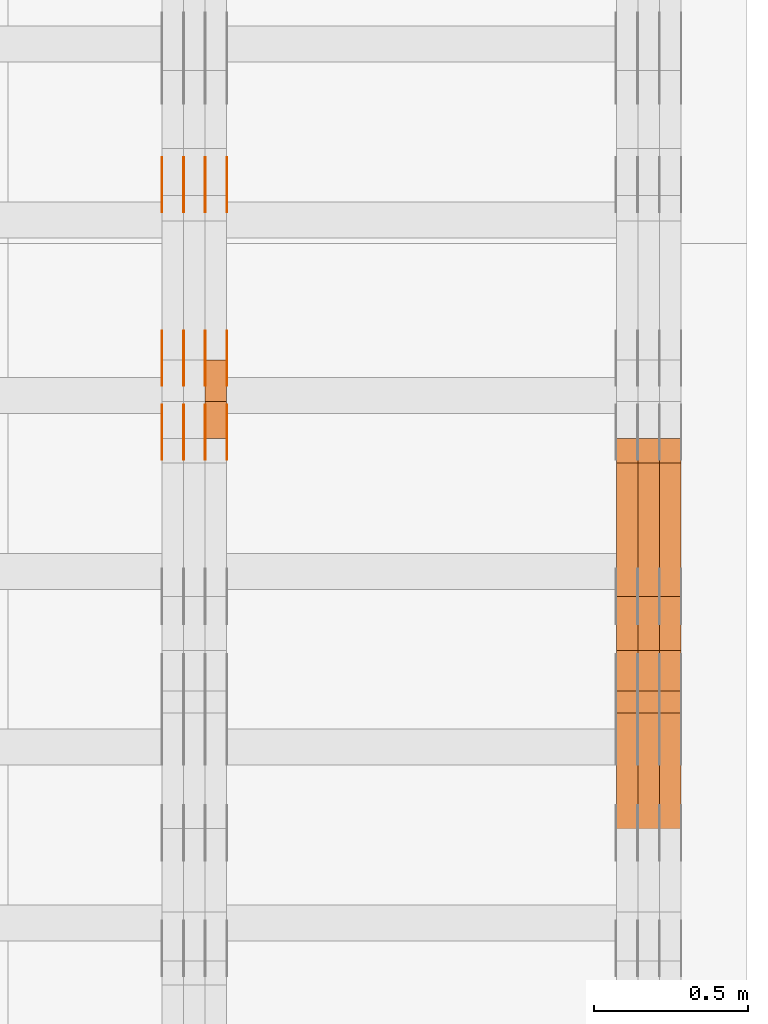
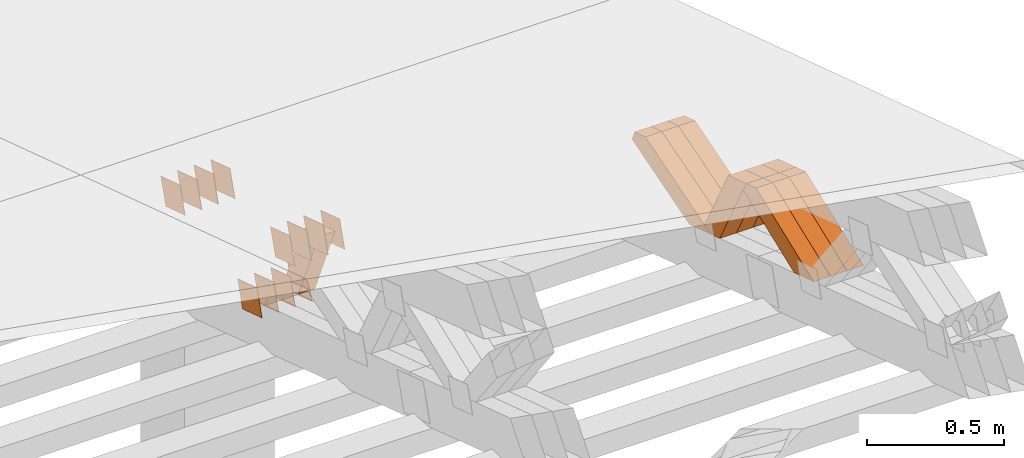
# One storey, part 371 of 385: 28 proxies.
"""IFC2X3 building model written with IfcOpenShell, lengths in millimetres."""

from ifc_helpers import new_model, entity, si_unit, converted_unit, derived_unit, direction, frame, origin, place, context, subcontext, project, spatial, polyline, outline, extrude, source, transform, mapped, material, type_object, type_shapes, element, save


model = new_model("IFC2X3")

# Units and contexts
model_context = context("Model", 3, precision=0.01, world=origin(), true_north=direction((6.12303176911189e-17, 1.0)))
body_context = subcontext(model_context, "Body", "Model", "MODEL_VIEW")
ifc_project = project(units=[si_unit("LENGTHUNIT", "METRE", prefix="MILLI"), si_unit("AREAUNIT", "SQUARE_METRE"), si_unit("VOLUMEUNIT", "CUBIC_METRE"), converted_unit("PLANEANGLEUNIT", "DEGREE", entity("IfcRatioMeasure", 0.0174532925199433), si_unit("PLANEANGLEUNIT", "RADIAN"), dimensions=[0, 0, 0, 0, 0, 0, 0]), si_unit("MASSUNIT", "GRAM", prefix="KILO"), derived_unit("MASSDENSITYUNIT", [(si_unit("MASSUNIT", "GRAM", prefix="KILO"), 1), (si_unit("LENGTHUNIT", "METRE"), -3)]), si_unit("TIMEUNIT", "SECOND"), si_unit("FREQUENCYUNIT", "HERTZ"), si_unit("THERMODYNAMICTEMPERATUREUNIT", "DEGREE_CELSIUS"), derived_unit("THERMALTRANSMITTANCEUNIT", [(si_unit("MASSUNIT", "GRAM", prefix="KILO"), 1), (si_unit("THERMODYNAMICTEMPERATUREUNIT", "KELVIN"), -1), (si_unit("TIMEUNIT", "SECOND"), -3)]), derived_unit("VOLUMETRICFLOWRATEUNIT", [(si_unit("LENGTHUNIT", "METRE"), 3), (si_unit("TIMEUNIT", "SECOND"), -1)]), si_unit("ELECTRICCURRENTUNIT", "AMPERE"), si_unit("ELECTRICVOLTAGEUNIT", "VOLT"), si_unit("POWERUNIT", "WATT"), si_unit("FORCEUNIT", "NEWTON", prefix="KILO"), si_unit("ILLUMINANCEUNIT", "LUX"), si_unit("LUMINOUSFLUXUNIT", "LUMEN"), si_unit("LUMINOUSINTENSITYUNIT", "CANDELA"), derived_unit("USERDEFINED", [(si_unit("MASSUNIT", "GRAM", prefix="KILO"), -1), (si_unit("LENGTHUNIT", "METRE"), -2), (si_unit("TIMEUNIT", "SECOND"), 3), (si_unit("LUMINOUSFLUXUNIT", "LUMEN"), 1)]), derived_unit("LINEARVELOCITYUNIT", [(si_unit("LENGTHUNIT", "METRE"), 1), (si_unit("TIMEUNIT", "SECOND"), -1)]), si_unit("PRESSUREUNIT", "PASCAL"), derived_unit("USERDEFINED", [(si_unit("LENGTHUNIT", "METRE"), -2), (si_unit("MASSUNIT", "GRAM", prefix="KILO"), 1), (si_unit("TIMEUNIT", "SECOND"), -2)])], contexts=[model_context])

# Site, building, storey
site_placement = place(None, origin())
site = spatial("IfcSite", under=ifc_project, at=site_placement, CompositionType="ELEMENT")
building_placement = place(site_placement, origin())
building = spatial("IfcBuilding", under=site, at=building_placement, CompositionType="ELEMENT")
storey_placement = place(building_placement, origin())
storey = spatial("IfcBuildingStorey", under=building, at=storey_placement, Name="Default", CompositionType="ELEMENT", Elevation=0.0)

# Proxies
ifc_material_1 = material(Name="IfcSurfaceStyle #598006")
building_element_proxy_type_1 = type_object("IfcBuildingElementProxyType", Name="T2-W30 598004", PredefinedType="NOTDEFINED", material=ifc_material_1)
shared_shape_1 = source(origin(), body_context, "Body", "SweptSolid", [
    extrude(outline(polyline([(-319.322304176575, -47.5000259045904), (133.154090927094, -47.5000259045904), (191.489196707701, 6.99403755251016e-06), (197.330697834052, 47.5000224075717), (-202.651681292271, 47.5000224075717), (-319.322304176575, -47.5000259045904)])), frame((197.330834478517, 47.5000608592405, 0.0), z_axis=(0.0, 0.0, 1.0), x_axis=(-1.0, 0.0, 0.0)), (0.0, 0.0, 1.0), 70.0),
])
type_shapes(building_element_proxy_type_1, [shared_shape_1])
proxy_1_placement = place(building_placement, frame((49860.0, 22312.5352975627, 1720.70362673362), z_axis=(-1.0, 0.0, 0.0), x_axis=(0.0, -0.932610696879359, -0.360884036868072)))
element("IfcBuildingElementProxy", 1, at=proxy_1_placement, inside=storey, type_object=building_element_proxy_type_1, material=ifc_material_1, Name="T2-W30", context=body_context, shape_type="MappedRepresentation", body=[
    mapped(shared_shape_1, transform((0.0, 0.0, 0.0), scale=1.0)),
])
ifc_material_2 = material(Name="IfcSurfaceStyle #597940")
building_element_proxy_type_2 = type_object("IfcBuildingElementProxyType", Name="T2-W30 597938", PredefinedType="NOTDEFINED", material=ifc_material_2)
shared_shape_2 = source(origin(), body_context, "Body", "SweptSolid", [
    extrude(outline(polyline([(-319.322304176575, -47.5000259045904), (133.154090927094, -47.5000259045904), (191.489196707701, 6.99403755251016e-06), (197.330697834052, 47.5000224075717), (-202.651681292271, 47.5000224075717), (-319.322304176575, -47.5000259045904)])), frame((197.330834478517, 47.5000608592405, 0.0), z_axis=(0.0, 0.0, 1.0), x_axis=(-1.0, 0.0, 0.0)), (0.0, 0.0, 1.0), 70.0),
])
type_shapes(building_element_proxy_type_2, [shared_shape_2])
proxy_2_placement = place(building_placement, frame((49790.0, 22312.5352975627, 1720.70362673362), z_axis=(-1.0, 0.0, 0.0), x_axis=(0.0, -0.932610696879359, -0.360884036868072)))
element("IfcBuildingElementProxy", 2, at=proxy_2_placement, inside=storey, type_object=building_element_proxy_type_2, material=ifc_material_2, Name="T2-W30", context=body_context, shape_type="MappedRepresentation", body=[
    mapped(shared_shape_2, transform((0.0, 0.0, 0.0), scale=1.0)),
])
ifc_material_3 = material(Name="IfcSurfaceStyle #597874")
building_element_proxy_type_3 = type_object("IfcBuildingElementProxyType", Name="T2-W30 597872", PredefinedType="NOTDEFINED", material=ifc_material_3)
shared_shape_3 = source(origin(), body_context, "Body", "SweptSolid", [
    extrude(outline(polyline([(-319.322304176575, -47.5000259045904), (133.154090927094, -47.5000259045904), (191.489196707701, 6.99403755251016e-06), (197.330697834052, 47.5000224075717), (-202.651681292271, 47.5000224075717), (-319.322304176575, -47.5000259045904)])), frame((197.330834478517, 47.5000608592405, 0.0), z_axis=(0.0, 0.0, 1.0), x_axis=(-1.0, 0.0, 0.0)), (0.0, 0.0, 1.0), 70.0),
])
type_shapes(building_element_proxy_type_3, [shared_shape_3])
proxy_3_placement = place(building_placement, frame((49720.0, 22312.5352975627, 1720.70362673362), z_axis=(-1.0, 0.0, 0.0), x_axis=(0.0, -0.932610696879359, -0.360884036868072)))
element("IfcBuildingElementProxy", 3, at=proxy_3_placement, inside=storey, type_object=building_element_proxy_type_3, material=ifc_material_3, Name="T2-W30", context=body_context, shape_type="MappedRepresentation", body=[
    mapped(shared_shape_3, transform((0.0, 0.0, 0.0), scale=1.0)),
])
ifc_material_4 = material(Name="IfcSurfaceStyle #597610")
building_element_proxy_type_4 = type_object("IfcBuildingElementProxyType", Name="T2-W41 597608", PredefinedType="NOTDEFINED", material=ifc_material_4)
shared_shape_4 = source(origin(), body_context, "Body", "SweptSolid", [
    extrude(outline(polyline([(-190.064783497519, -47.5001011048749), (182.590736871656, -47.5001011048749), (172.978793750747, 0.000111395300689243), (123.505951450908, 47.5000454072246), (-289.010698575792, 47.5000454072246), (-190.064783497519, -47.5001011048749)])), frame((182.590736871656, 47.5001973817447, 0.0), z_axis=(0.0, 0.0, 1.0), x_axis=(-1.0, 0.0, 0.0)), (0.0, 0.0, 1.0), 70.0),
])
type_shapes(building_element_proxy_type_4, [shared_shape_4])
proxy_4_placement = place(building_placement, frame((49860.0, 22512.5506969063, 1347.13648051689), z_axis=(-1.0, 0.0, 0.0), x_axis=(0.0, -0.472020158706979, 0.881587755004706)))
element("IfcBuildingElementProxy", 4, at=proxy_4_placement, inside=storey, type_object=building_element_proxy_type_4, material=ifc_material_4, Name="T2-W41", context=body_context, shape_type="MappedRepresentation", body=[
    mapped(shared_shape_4, transform((0.0, 0.0, 0.0), scale=1.0)),
])
ifc_material_5 = material(Name="IfcSurfaceStyle #597544")
building_element_proxy_type_5 = type_object("IfcBuildingElementProxyType", Name="T2-W41 597542", PredefinedType="NOTDEFINED", material=ifc_material_5)
shared_shape_5 = source(origin(), body_context, "Body", "SweptSolid", [
    extrude(outline(polyline([(-190.064783497519, -47.5001011048749), (182.590736871656, -47.5001011048749), (172.978793750747, 0.000111395300689243), (123.505951450908, 47.5000454072246), (-289.010698575792, 47.5000454072246), (-190.064783497519, -47.5001011048749)])), frame((182.590736871656, 47.5001973817447, 0.0), z_axis=(0.0, 0.0, 1.0), x_axis=(-1.0, 0.0, 0.0)), (0.0, 0.0, 1.0), 70.0),
])
type_shapes(building_element_proxy_type_5, [shared_shape_5])
proxy_5_placement = place(building_placement, frame((49790.0, 22512.5506969063, 1347.13648051689), z_axis=(-1.0, 0.0, 0.0), x_axis=(0.0, -0.472020158706979, 0.881587755004706)))
element("IfcBuildingElementProxy", 5, at=proxy_5_placement, inside=storey, type_object=building_element_proxy_type_5, material=ifc_material_5, Name="T2-W41", context=body_context, shape_type="MappedRepresentation", body=[
    mapped(shared_shape_5, transform((0.0, 0.0, 0.0), scale=1.0)),
])
ifc_material_6 = material(Name="IfcSurfaceStyle #597478")
building_element_proxy_type_6 = type_object("IfcBuildingElementProxyType", Name="T2-W41 597476", PredefinedType="NOTDEFINED", material=ifc_material_6)
shared_shape_6 = source(origin(), body_context, "Body", "SweptSolid", [
    extrude(outline(polyline([(-190.064783497519, -47.5001011048749), (182.590736871656, -47.5001011048749), (172.978793750747, 0.000111395300689243), (123.505951450908, 47.5000454072246), (-289.010698575792, 47.5000454072246), (-190.064783497519, -47.5001011048749)])), frame((182.590736871656, 47.5001973817447, 0.0), z_axis=(0.0, 0.0, 1.0), x_axis=(-1.0, 0.0, 0.0)), (0.0, 0.0, 1.0), 70.0),
])
type_shapes(building_element_proxy_type_6, [shared_shape_6])
proxy_6_placement = place(building_placement, frame((49720.0, 22512.5506969063, 1347.13648051689), z_axis=(-1.0, 0.0, 0.0), x_axis=(0.0, -0.472020158706979, 0.881587755004706)))
element("IfcBuildingElementProxy", 6, at=proxy_6_placement, inside=storey, type_object=building_element_proxy_type_6, material=ifc_material_6, Name="T2-W41", context=body_context, shape_type="MappedRepresentation", body=[
    mapped(shared_shape_6, transform((0.0, 0.0, 0.0), scale=1.0)),
])
ifc_material_7 = material(Name="IfcSurfaceStyle #597214")
building_element_proxy_type_7 = type_object("IfcBuildingElementProxyType", Name="T2-W23 597212", PredefinedType="NOTDEFINED", material=ifc_material_7)
shared_shape_7 = source(origin(), body_context, "Body", "SweptSolid", [
    extrude(outline(polyline([(-356.808656505462, -47.5000180192671), (144.726334557508, -47.5000180192671), (213.258834104997, -2.90494310381195e-05), (218.567145253444, 47.5000325439826), (-219.743657410487, 47.5000325439827), (-356.808656505462, -47.5000180192671)])), frame((218.567145253444, 47.5000325439826, 0.0), z_axis=(0.0, 0.0, 1.0), x_axis=(-1.0, 0.0, 0.0)), (0.0, 0.0, 1.0), 70.0),
])
type_shapes(building_element_proxy_type_7, [shared_shape_7])
proxy_7_placement = place(building_placement, frame((49860.0, 23128.2626953125, 1452.63940429688), z_axis=(-1.0, 0.0, 0.0), x_axis=(0.0, -0.957692700226705, -0.287792793399143)))
element("IfcBuildingElementProxy", 7, at=proxy_7_placement, inside=storey, type_object=building_element_proxy_type_7, material=ifc_material_7, Name="T2-W23", context=body_context, shape_type="MappedRepresentation", body=[
    mapped(shared_shape_7, transform((0.0, 0.0, 0.0), scale=1.0)),
])
ifc_material_8 = material(Name="IfcSurfaceStyle #597148")
building_element_proxy_type_8 = type_object("IfcBuildingElementProxyType", Name="T2-W23 597146", PredefinedType="NOTDEFINED", material=ifc_material_8)
shared_shape_8 = source(origin(), body_context, "Body", "SweptSolid", [
    extrude(outline(polyline([(-356.808656505462, -47.5000180192671), (144.726334557508, -47.5000180192671), (213.258834104997, -2.90494310381195e-05), (218.567145253444, 47.5000325439826), (-219.743657410487, 47.5000325439827), (-356.808656505462, -47.5000180192671)])), frame((218.567145253444, 47.5000325439826, 0.0), z_axis=(0.0, 0.0, 1.0), x_axis=(-1.0, 0.0, 0.0)), (0.0, 0.0, 1.0), 70.0),
])
type_shapes(building_element_proxy_type_8, [shared_shape_8])
proxy_8_placement = place(building_placement, frame((49790.0, 23128.2626953125, 1452.63940429688), z_axis=(-1.0, 0.0, 0.0), x_axis=(0.0, -0.957692700226705, -0.287792793399143)))
element("IfcBuildingElementProxy", 8, at=proxy_8_placement, inside=storey, type_object=building_element_proxy_type_8, material=ifc_material_8, Name="T2-W23", context=body_context, shape_type="MappedRepresentation", body=[
    mapped(shared_shape_8, transform((0.0, 0.0, 0.0), scale=1.0)),
])
ifc_material_9 = material(Name="IfcSurfaceStyle #597082")
building_element_proxy_type_9 = type_object("IfcBuildingElementProxyType", Name="T2-W23 597080", PredefinedType="NOTDEFINED", material=ifc_material_9)
shared_shape_9 = source(origin(), body_context, "Body", "SweptSolid", [
    extrude(outline(polyline([(-356.808656505462, -47.5000180192671), (144.726334557508, -47.5000180192671), (213.258834104997, -2.90494310381195e-05), (218.567145253444, 47.5000325439826), (-219.743657410487, 47.5000325439827), (-356.808656505462, -47.5000180192671)])), frame((218.567145253444, 47.5000325439826, 0.0), z_axis=(0.0, 0.0, 1.0), x_axis=(-1.0, 0.0, 0.0)), (0.0, 0.0, 1.0), 70.0),
])
type_shapes(building_element_proxy_type_9, [shared_shape_9])
proxy_9_placement = place(building_placement, frame((49720.0, 23128.2626953125, 1452.63940429688), z_axis=(-1.0, 0.0, 0.0), x_axis=(0.0, -0.957692700226705, -0.287792793399143)))
element("IfcBuildingElementProxy", 9, at=proxy_9_placement, inside=storey, type_object=building_element_proxy_type_9, material=ifc_material_9, Name="T2-W23", context=body_context, shape_type="MappedRepresentation", body=[
    mapped(shared_shape_9, transform((0.0, 0.0, 0.0), scale=1.0)),
])
ifc_material_10 = material(Name="IfcSurfaceStyle #575238")
building_element_proxy_type_10 = type_object("IfcBuildingElementProxyType", PredefinedType="NOTDEFINED", material=ifc_material_10)
shared_shape_10 = source(origin(), body_context, "Body", "SweptSolid", [
    extrude(outline(polyline([(-74.9998888504569, -59.9999264677525), (74.999884859074, -59.9999264677525), (74.9998699895559, 59.9999264677525), (-74.999865998173, 59.9999264677525), (-74.9998888504569, -59.9999264677525)])), frame((74.9999170714918, 60.0000016373507, 0.0), z_axis=(0.0, 0.0, 1.0), x_axis=(-1.0, 0.0, 0.0)), (0.0, 0.0, 1.0), 1.3),
])
type_shapes(building_element_proxy_type_10, [shared_shape_10])
proxy_10_placement = place(building_placement, frame((48386.3, 23182.5962361838, 1409.76695322432), z_axis=(-1.0, 0.0, 0.0), x_axis=(0.0, -0.951056516295154, 0.309016994374948)))
element("IfcBuildingElementProxy", 10, at=proxy_10_placement, inside=storey, type_object=building_element_proxy_type_10, material=ifc_material_10, context=body_context, shape_type="MappedRepresentation", body=[
    mapped(shared_shape_10, transform((0.0, 0.0, 0.0), scale=1.0)),
])
ifc_material_11 = material(Name="IfcSurfaceStyle #575181")
building_element_proxy_type_11 = type_object("IfcBuildingElementProxyType", PredefinedType="NOTDEFINED", material=ifc_material_11)
shared_shape_11 = source(origin(), body_context, "Body", "SweptSolid", [
    extrude(outline(polyline([(-74.9998888504569, -59.9999264677525), (74.999884859074, -59.9999264677525), (74.9998699895559, 59.9999264677525), (-74.999865998173, 59.9999264677525), (-74.9998888504569, -59.9999264677525)])), frame((74.9999170714918, 60.0000016373507, 0.0), z_axis=(0.0, 0.0, 1.0), x_axis=(-1.0, 0.0, 0.0)), (0.0, 0.0, 1.0), 1.3),
])
type_shapes(building_element_proxy_type_11, [shared_shape_11])
proxy_11_placement = place(building_placement, frame((48315.0, 23182.5962361838, 1409.76695322432), z_axis=(-1.0, 0.0, 0.0), x_axis=(0.0, -0.951056516295154, 0.309016994374948)))
element("IfcBuildingElementProxy", 11, at=proxy_11_placement, inside=storey, type_object=building_element_proxy_type_11, material=ifc_material_11, context=body_context, shape_type="MappedRepresentation", body=[
    mapped(shared_shape_11, transform((0.0, 0.0, 0.0), scale=1.0)),
])
ifc_material_12 = material(Name="IfcSurfaceStyle #575124")
building_element_proxy_type_12 = type_object("IfcBuildingElementProxyType", PredefinedType="NOTDEFINED", material=ifc_material_12)
shared_shape_12 = source(origin(), body_context, "Body", "SweptSolid", [
    extrude(outline(polyline([(-74.9998888504569, -59.9999264677525), (74.999884859074, -59.9999264677525), (74.9998699895559, 59.9999264677525), (-74.999865998173, 59.9999264677525), (-74.9998888504569, -59.9999264677525)])), frame((74.9999170714918, 60.0000016373507, 0.0), z_axis=(0.0, 0.0, 1.0), x_axis=(-1.0, 0.0, 0.0)), (0.0, 0.0, 1.0), 1.3),
])
type_shapes(building_element_proxy_type_12, [shared_shape_12])
proxy_12_placement = place(building_placement, frame((48316.3, 23182.5962361838, 1409.76695322432), z_axis=(-1.0, 0.0, 0.0), x_axis=(0.0, -0.951056516295154, 0.309016994374948)))
element("IfcBuildingElementProxy", 12, at=proxy_12_placement, inside=storey, type_object=building_element_proxy_type_12, material=ifc_material_12, context=body_context, shape_type="MappedRepresentation", body=[
    mapped(shared_shape_12, transform((0.0, 0.0, 0.0), scale=1.0)),
])
ifc_material_13 = material(Name="IfcSurfaceStyle #575067")
building_element_proxy_type_13 = type_object("IfcBuildingElementProxyType", PredefinedType="NOTDEFINED", material=ifc_material_13)
shared_shape_13 = source(origin(), body_context, "Body", "SweptSolid", [
    extrude(outline(polyline([(-74.9998888504569, -59.9999264677525), (74.999884859074, -59.9999264677525), (74.9998699895559, 59.9999264677525), (-74.999865998173, 59.9999264677525), (-74.9998888504569, -59.9999264677525)])), frame((74.9999170714918, 60.0000016373507, 0.0), z_axis=(0.0, 0.0, 1.0), x_axis=(-1.0, 0.0, 0.0)), (0.0, 0.0, 1.0), 1.29999999999999),
])
type_shapes(building_element_proxy_type_13, [shared_shape_13])
proxy_13_placement = place(building_placement, frame((48245.0, 23182.5962361838, 1409.76695322432), z_axis=(-1.0, 0.0, 0.0), x_axis=(0.0, -0.951056516295154, 0.309016994374948)))
element("IfcBuildingElementProxy", 13, at=proxy_13_placement, inside=storey, type_object=building_element_proxy_type_13, material=ifc_material_13, context=body_context, shape_type="MappedRepresentation", body=[
    mapped(shared_shape_13, transform((0.0, 0.0, 0.0), scale=1.0)),
])
ifc_material_14 = material(Name="IfcSurfaceStyle #575010")
building_element_proxy_type_14 = type_object("IfcBuildingElementProxyType", PredefinedType="NOTDEFINED", material=ifc_material_14)
shared_shape_14 = source(origin(), body_context, "Body", "SweptSolid", [
    extrude(outline(polyline([(-74.9998888504569, -59.9999264677525), (74.999884859074, -59.9999264677525), (74.9998699895559, 59.9999264677525), (-74.999865998173, 59.9999264677525), (-74.9998888504569, -59.9999264677525)])), frame((74.9999170714918, 60.0000016373507, 0.0), z_axis=(0.0, 0.0, 1.0), x_axis=(-1.0, 0.0, 0.0)), (0.0, 0.0, 1.0), 1.29999999999999),
])
type_shapes(building_element_proxy_type_14, [shared_shape_14])
proxy_14_placement = place(building_placement, frame((48246.3, 23182.5962361838, 1409.76695322432), z_axis=(-1.0, 0.0, 0.0), x_axis=(0.0, -0.951056516295154, 0.309016994374948)))
element("IfcBuildingElementProxy", 14, at=proxy_14_placement, inside=storey, type_object=building_element_proxy_type_14, material=ifc_material_14, context=body_context, shape_type="MappedRepresentation", body=[
    mapped(shared_shape_14, transform((0.0, 0.0, 0.0), scale=1.0)),
])
ifc_material_15 = material(Name="IfcSurfaceStyle #574953")
building_element_proxy_type_15 = type_object("IfcBuildingElementProxyType", PredefinedType="NOTDEFINED", material=ifc_material_15)
shared_shape_15 = source(origin(), body_context, "Body", "SweptSolid", [
    extrude(outline(polyline([(-74.9998888504569, -59.9999264677525), (74.999884859074, -59.9999264677525), (74.9998699895559, 59.9999264677525), (-74.999865998173, 59.9999264677525), (-74.9998888504569, -59.9999264677525)])), frame((74.9999170714918, 60.0000016373507, 0.0), z_axis=(0.0, 0.0, 1.0), x_axis=(-1.0, 0.0, 0.0)), (0.0, 0.0, 1.0), 1.29999999999999),
])
type_shapes(building_element_proxy_type_15, [shared_shape_15])
proxy_15_placement = place(building_placement, frame((48175.0, 23182.5962361838, 1409.76695322432), z_axis=(-1.0, 0.0, 0.0), x_axis=(0.0, -0.951056516295154, 0.309016994374948)))
element("IfcBuildingElementProxy", 15, at=proxy_15_placement, inside=storey, type_object=building_element_proxy_type_15, material=ifc_material_15, context=body_context, shape_type="MappedRepresentation", body=[
    mapped(shared_shape_15, transform((0.0, 0.0, 0.0), scale=1.0)),
])
ifc_material_16 = material(Name="IfcSurfaceStyle #574896")
building_element_proxy_type_16 = type_object("IfcBuildingElementProxyType", PredefinedType="NOTDEFINED", material=ifc_material_16)
shared_shape_16 = source(origin(), body_context, "Body", "SweptSolid", [
    extrude(outline(polyline([(-75.000111611545, -60.0000599592451), (75.0000887592491, -60.0000599592451), (75.000111611545, 60.0000599592451), (-75.0000887592492, 60.0000599592451), (-75.000111611545, -60.0000599592451)])), frame((75.000111611545, 60.0000599592451, 0.0), z_axis=(0.0, 0.0, 1.0), x_axis=(-1.0, 0.0, 0.0)), (0.0, 0.0, 1.0), 1.3),
])
type_shapes(building_element_proxy_type_16, [shared_shape_16])
proxy_16_placement = place(building_placement, frame((48386.3, 23422.738257852, 1031.33757447264), z_axis=(-1.0, 0.0, 0.0), x_axis=(0.0, -0.951056516295124, 0.309016994375039)))
element("IfcBuildingElementProxy", 16, at=proxy_16_placement, inside=storey, type_object=building_element_proxy_type_16, material=ifc_material_16, context=body_context, shape_type="MappedRepresentation", body=[
    mapped(shared_shape_16, transform((0.0, 0.0, 0.0), scale=1.0)),
])
ifc_material_17 = material(Name="IfcSurfaceStyle #574839")
building_element_proxy_type_17 = type_object("IfcBuildingElementProxyType", PredefinedType="NOTDEFINED", material=ifc_material_17)
shared_shape_17 = source(origin(), body_context, "Body", "SweptSolid", [
    extrude(outline(polyline([(-75.000111611545, -60.0000599592451), (75.0000887592491, -60.0000599592451), (75.000111611545, 60.0000599592451), (-75.0000887592492, 60.0000599592451), (-75.000111611545, -60.0000599592451)])), frame((75.000111611545, 60.0000599592451, 0.0), z_axis=(0.0, 0.0, 1.0), x_axis=(-1.0, 0.0, 0.0)), (0.0, 0.0, 1.0), 1.3),
])
type_shapes(building_element_proxy_type_17, [shared_shape_17])
proxy_17_placement = place(building_placement, frame((48315.0, 23422.738257852, 1031.33757447264), z_axis=(-1.0, 0.0, 0.0), x_axis=(0.0, -0.951056516295124, 0.309016994375039)))
element("IfcBuildingElementProxy", 17, at=proxy_17_placement, inside=storey, type_object=building_element_proxy_type_17, material=ifc_material_17, context=body_context, shape_type="MappedRepresentation", body=[
    mapped(shared_shape_17, transform((0.0, 0.0, 0.0), scale=1.0)),
])
ifc_material_18 = material(Name="IfcSurfaceStyle #574782")
building_element_proxy_type_18 = type_object("IfcBuildingElementProxyType", PredefinedType="NOTDEFINED", material=ifc_material_18)
shared_shape_18 = source(origin(), body_context, "Body", "SweptSolid", [
    extrude(outline(polyline([(-75.000111611545, -60.0000599592451), (75.0000887592491, -60.0000599592451), (75.000111611545, 60.0000599592451), (-75.0000887592492, 60.0000599592451), (-75.000111611545, -60.0000599592451)])), frame((75.000111611545, 60.0000599592451, 0.0), z_axis=(0.0, 0.0, 1.0), x_axis=(-1.0, 0.0, 0.0)), (0.0, 0.0, 1.0), 1.3),
])
type_shapes(building_element_proxy_type_18, [shared_shape_18])
proxy_18_placement = place(building_placement, frame((48316.3, 23422.738257852, 1031.33757447264), z_axis=(-1.0, 0.0, 0.0), x_axis=(0.0, -0.951056516295124, 0.309016994375039)))
element("IfcBuildingElementProxy", 18, at=proxy_18_placement, inside=storey, type_object=building_element_proxy_type_18, material=ifc_material_18, context=body_context, shape_type="MappedRepresentation", body=[
    mapped(shared_shape_18, transform((0.0, 0.0, 0.0), scale=1.0)),
])
ifc_material_19 = material(Name="IfcSurfaceStyle #574725")
building_element_proxy_type_19 = type_object("IfcBuildingElementProxyType", PredefinedType="NOTDEFINED", material=ifc_material_19)
shared_shape_19 = source(origin(), body_context, "Body", "SweptSolid", [
    extrude(outline(polyline([(-75.000111611545, -60.0000599592451), (75.0000887592491, -60.0000599592451), (75.000111611545, 60.0000599592451), (-75.0000887592492, 60.0000599592451), (-75.000111611545, -60.0000599592451)])), frame((75.000111611545, 60.0000599592451, 0.0), z_axis=(0.0, 0.0, 1.0), x_axis=(-1.0, 0.0, 0.0)), (0.0, 0.0, 1.0), 1.29999999999999),
])
type_shapes(building_element_proxy_type_19, [shared_shape_19])
proxy_19_placement = place(building_placement, frame((48245.0, 23422.738257852, 1031.33757447264), z_axis=(-1.0, 0.0, 0.0), x_axis=(0.0, -0.951056516295124, 0.309016994375039)))
element("IfcBuildingElementProxy", 19, at=proxy_19_placement, inside=storey, type_object=building_element_proxy_type_19, material=ifc_material_19, context=body_context, shape_type="MappedRepresentation", body=[
    mapped(shared_shape_19, transform((0.0, 0.0, 0.0), scale=1.0)),
])
ifc_material_20 = material(Name="IfcSurfaceStyle #574668")
building_element_proxy_type_20 = type_object("IfcBuildingElementProxyType", PredefinedType="NOTDEFINED", material=ifc_material_20)
shared_shape_20 = source(origin(), body_context, "Body", "SweptSolid", [
    extrude(outline(polyline([(-75.000111611545, -60.0000599592451), (75.0000887592491, -60.0000599592451), (75.000111611545, 60.0000599592451), (-75.0000887592492, 60.0000599592451), (-75.000111611545, -60.0000599592451)])), frame((75.000111611545, 60.0000599592451, 0.0), z_axis=(0.0, 0.0, 1.0), x_axis=(-1.0, 0.0, 0.0)), (0.0, 0.0, 1.0), 1.29999999999999),
])
type_shapes(building_element_proxy_type_20, [shared_shape_20])
proxy_20_placement = place(building_placement, frame((48246.3, 23422.738257852, 1031.33757447264), z_axis=(-1.0, 0.0, 0.0), x_axis=(0.0, -0.951056516295124, 0.309016994375039)))
element("IfcBuildingElementProxy", 20, at=proxy_20_placement, inside=storey, type_object=building_element_proxy_type_20, material=ifc_material_20, context=body_context, shape_type="MappedRepresentation", body=[
    mapped(shared_shape_20, transform((0.0, 0.0, 0.0), scale=1.0)),
])
ifc_material_21 = material(Name="IfcSurfaceStyle #574611")
building_element_proxy_type_21 = type_object("IfcBuildingElementProxyType", PredefinedType="NOTDEFINED", material=ifc_material_21)
shared_shape_21 = source(origin(), body_context, "Body", "SweptSolid", [
    extrude(outline(polyline([(-75.000111611545, -60.0000599592451), (75.0000887592491, -60.0000599592451), (75.000111611545, 60.0000599592451), (-75.0000887592492, 60.0000599592451), (-75.000111611545, -60.0000599592451)])), frame((75.000111611545, 60.0000599592451, 0.0), z_axis=(0.0, 0.0, 1.0), x_axis=(-1.0, 0.0, 0.0)), (0.0, 0.0, 1.0), 1.29999999999999),
])
type_shapes(building_element_proxy_type_21, [shared_shape_21])
proxy_21_placement = place(building_placement, frame((48175.0, 23422.738257852, 1031.33757447264), z_axis=(-1.0, 0.0, 0.0), x_axis=(0.0, -0.951056516295124, 0.309016994375039)))
element("IfcBuildingElementProxy", 21, at=proxy_21_placement, inside=storey, type_object=building_element_proxy_type_21, material=ifc_material_21, context=body_context, shape_type="MappedRepresentation", body=[
    mapped(shared_shape_21, transform((0.0, 0.0, 0.0), scale=1.0)),
])
ifc_material_22 = material(Name="IfcSurfaceStyle #574212")
building_element_proxy_type_22 = type_object("IfcBuildingElementProxyType", PredefinedType="NOTDEFINED", material=ifc_material_22)
shared_shape_22 = source(origin(), body_context, "Body", "SweptSolid", [
    extrude(outline(polyline([(-74.9999766548731, -60.0000019113547), (75.000223715922, -60.0000019113547), (74.9997444633404, 60.0000019113548), (-74.9999915243893, 60.0000019113547), (-74.9999766548731, -60.0000019113547)])), frame((75.0002237159219, 60.0000770809529, 0.0), z_axis=(0.0, 0.0, 1.0), x_axis=(-1.0, 0.0, 0.0)), (0.0, 0.0, 1.0), 1.3),
])
type_shapes(building_element_proxy_type_22, [shared_shape_22])
proxy_22_placement = place(building_placement, frame((48386.3, 23985.88473314, 1148.76266928562), z_axis=(-1.0, 0.0, 0.0), x_axis=(0.0, -0.951056516295154, 0.309016994374948)))
element("IfcBuildingElementProxy", 22, at=proxy_22_placement, inside=storey, type_object=building_element_proxy_type_22, material=ifc_material_22, context=body_context, shape_type="MappedRepresentation", body=[
    mapped(shared_shape_22, transform((0.0, 0.0, 0.0), scale=1.0)),
])
ifc_material_23 = material(Name="IfcSurfaceStyle #574155")
building_element_proxy_type_23 = type_object("IfcBuildingElementProxyType", PredefinedType="NOTDEFINED", material=ifc_material_23)
shared_shape_23 = source(origin(), body_context, "Body", "SweptSolid", [
    extrude(outline(polyline([(-74.9999766548731, -60.0000019113547), (75.000223715922, -60.0000019113547), (74.9997444633404, 60.0000019113548), (-74.9999915243893, 60.0000019113547), (-74.9999766548731, -60.0000019113547)])), frame((75.0002237159219, 60.0000770809529, 0.0), z_axis=(0.0, 0.0, 1.0), x_axis=(-1.0, 0.0, 0.0)), (0.0, 0.0, 1.0), 1.3),
])
type_shapes(building_element_proxy_type_23, [shared_shape_23])
proxy_23_placement = place(building_placement, frame((48315.0, 23985.88473314, 1148.76266928562), z_axis=(-1.0, 0.0, 0.0), x_axis=(0.0, -0.951056516295154, 0.309016994374948)))
element("IfcBuildingElementProxy", 23, at=proxy_23_placement, inside=storey, type_object=building_element_proxy_type_23, material=ifc_material_23, context=body_context, shape_type="MappedRepresentation", body=[
    mapped(shared_shape_23, transform((0.0, 0.0, 0.0), scale=1.0)),
])
ifc_material_24 = material(Name="IfcSurfaceStyle #574098")
building_element_proxy_type_24 = type_object("IfcBuildingElementProxyType", PredefinedType="NOTDEFINED", material=ifc_material_24)
shared_shape_24 = source(origin(), body_context, "Body", "SweptSolid", [
    extrude(outline(polyline([(-74.9999766548731, -60.0000019113547), (75.000223715922, -60.0000019113547), (74.9997444633404, 60.0000019113548), (-74.9999915243893, 60.0000019113547), (-74.9999766548731, -60.0000019113547)])), frame((75.0002237159219, 60.0000770809529, 0.0), z_axis=(0.0, 0.0, 1.0), x_axis=(-1.0, 0.0, 0.0)), (0.0, 0.0, 1.0), 1.3),
])
type_shapes(building_element_proxy_type_24, [shared_shape_24])
proxy_24_placement = place(building_placement, frame((48316.3, 23985.88473314, 1148.76266928562), z_axis=(-1.0, 0.0, 0.0), x_axis=(0.0, -0.951056516295154, 0.309016994374948)))
element("IfcBuildingElementProxy", 24, at=proxy_24_placement, inside=storey, type_object=building_element_proxy_type_24, material=ifc_material_24, context=body_context, shape_type="MappedRepresentation", body=[
    mapped(shared_shape_24, transform((0.0, 0.0, 0.0), scale=1.0)),
])
ifc_material_25 = material(Name="IfcSurfaceStyle #574041")
building_element_proxy_type_25 = type_object("IfcBuildingElementProxyType", PredefinedType="NOTDEFINED", material=ifc_material_25)
shared_shape_25 = source(origin(), body_context, "Body", "SweptSolid", [
    extrude(outline(polyline([(-74.9999766548731, -60.0000019113547), (75.000223715922, -60.0000019113547), (74.9997444633404, 60.0000019113548), (-74.9999915243893, 60.0000019113547), (-74.9999766548731, -60.0000019113547)])), frame((75.0002237159219, 60.0000770809529, 0.0), z_axis=(0.0, 0.0, 1.0), x_axis=(-1.0, 0.0, 0.0)), (0.0, 0.0, 1.0), 1.29999999999999),
])
type_shapes(building_element_proxy_type_25, [shared_shape_25])
proxy_25_placement = place(building_placement, frame((48245.0, 23985.88473314, 1148.76266928562), z_axis=(-1.0, 0.0, 0.0), x_axis=(0.0, -0.951056516295154, 0.309016994374948)))
element("IfcBuildingElementProxy", 25, at=proxy_25_placement, inside=storey, type_object=building_element_proxy_type_25, material=ifc_material_25, context=body_context, shape_type="MappedRepresentation", body=[
    mapped(shared_shape_25, transform((0.0, 0.0, 0.0), scale=1.0)),
])
ifc_material_26 = material(Name="IfcSurfaceStyle #573984")
building_element_proxy_type_26 = type_object("IfcBuildingElementProxyType", PredefinedType="NOTDEFINED", material=ifc_material_26)
shared_shape_26 = source(origin(), body_context, "Body", "SweptSolid", [
    extrude(outline(polyline([(-74.9999766548731, -60.0000019113547), (75.000223715922, -60.0000019113547), (74.9997444633404, 60.0000019113548), (-74.9999915243893, 60.0000019113547), (-74.9999766548731, -60.0000019113547)])), frame((75.0002237159219, 60.0000770809529, 0.0), z_axis=(0.0, 0.0, 1.0), x_axis=(-1.0, 0.0, 0.0)), (0.0, 0.0, 1.0), 1.29999999999999),
])
type_shapes(building_element_proxy_type_26, [shared_shape_26])
proxy_26_placement = place(building_placement, frame((48246.3, 23985.88473314, 1148.76266928562), z_axis=(-1.0, 0.0, 0.0), x_axis=(0.0, -0.951056516295154, 0.309016994374948)))
element("IfcBuildingElementProxy", 26, at=proxy_26_placement, inside=storey, type_object=building_element_proxy_type_26, material=ifc_material_26, context=body_context, shape_type="MappedRepresentation", body=[
    mapped(shared_shape_26, transform((0.0, 0.0, 0.0), scale=1.0)),
])
ifc_material_27 = material(Name="IfcSurfaceStyle #573927")
building_element_proxy_type_27 = type_object("IfcBuildingElementProxyType", PredefinedType="NOTDEFINED", material=ifc_material_27)
shared_shape_27 = source(origin(), body_context, "Body", "SweptSolid", [
    extrude(outline(polyline([(-74.9999766548731, -60.0000019113547), (75.000223715922, -60.0000019113547), (74.9997444633404, 60.0000019113548), (-74.9999915243893, 60.0000019113547), (-74.9999766548731, -60.0000019113547)])), frame((75.0002237159219, 60.0000770809529, 0.0), z_axis=(0.0, 0.0, 1.0), x_axis=(-1.0, 0.0, 0.0)), (0.0, 0.0, 1.0), 1.29999999999999),
])
type_shapes(building_element_proxy_type_27, [shared_shape_27])
proxy_27_placement = place(building_placement, frame((48175.0, 23985.88473314, 1148.76266928562), z_axis=(-1.0, 0.0, 0.0), x_axis=(0.0, -0.951056516295154, 0.309016994374948)))
element("IfcBuildingElementProxy", 27, at=proxy_27_placement, inside=storey, type_object=building_element_proxy_type_27, material=ifc_material_27, context=body_context, shape_type="MappedRepresentation", body=[
    mapped(shared_shape_27, transform((0.0, 0.0, 0.0), scale=1.0)),
])
ifc_material_28 = material(Name="IfcSurfaceStyle #562386")
building_element_proxy_type_28 = type_object("IfcBuildingElementProxyType", Name="T1-W48 562384", PredefinedType="NOTDEFINED", material=ifc_material_28)
shared_shape_28 = source(origin(), body_context, "Body", "SweptSolid", [
    extrude(outline(polyline([(-179.014659681673, -47.5001725722734), (164.970934255612, -47.5001725722734), (158.689466064455, -0.000154807462590734), (117.249257288395, 47.5002499760047), (-261.894997926789, 47.5002499760047), (-179.014659681673, -47.5001725722734)])), frame((164.970934255612, 47.5002499760047, 0.0), z_axis=(0.0, 0.0, 1.0), x_axis=(-1.0, 0.0, 0.0)), (0.0, 0.0, 1.0), 70.0),
])
type_shapes(building_element_proxy_type_28, [shared_shape_28])
proxy_28_placement = place(building_placement, frame((48385.0, 23276.999081075, 1103.96808602322), z_axis=(-1.0, 0.0, 0.0), x_axis=(0.0, -0.392372359952232, 0.919806463961586)))
element("IfcBuildingElementProxy", 28, at=proxy_28_placement, inside=storey, type_object=building_element_proxy_type_28, material=ifc_material_28, Name="T1-W48", context=body_context, shape_type="MappedRepresentation", body=[
    mapped(shared_shape_28, transform((0.0, 0.0, 0.0), scale=1.0)),
])

save(model, "model.ifc")
